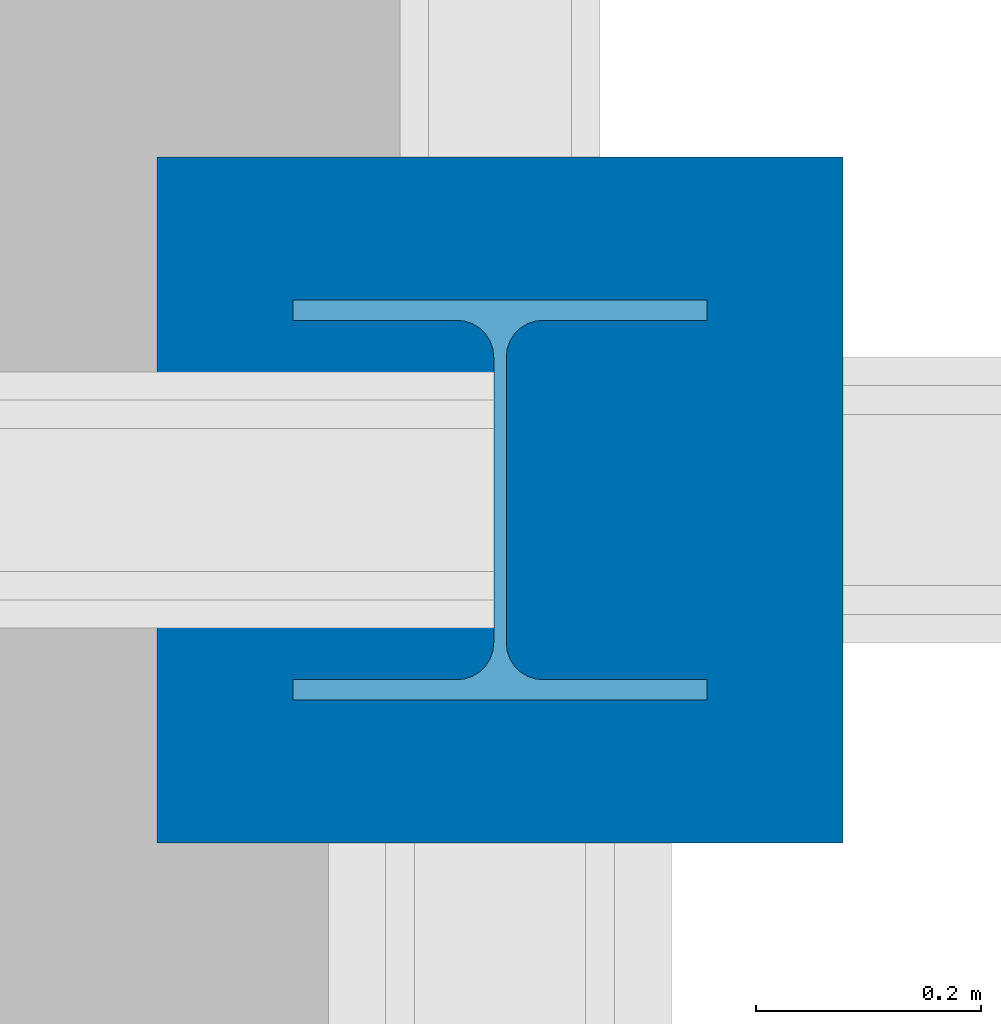
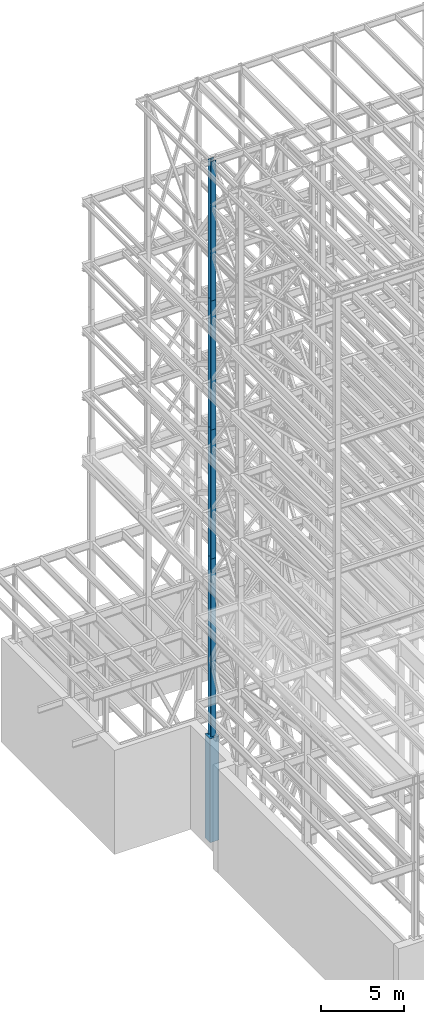
# One storey, part 14 of 150: 5 columns.
"""IFC2X3 building model written with IfcOpenShell, lengths in millimetres."""

from ifc_helpers import new_model, si_unit, frame, origin_with_axes, origin_2d_with_axis, place, context, subcontext, project, spatial, rectangle, i_section, extrude, material, type_object, element, save


model = new_model("IFC2X3")

# Units and contexts
model_context = context("Model", 3, precision=1e-05, world=origin_with_axes())
body_context = subcontext(model_context, "Body", "Model", "MODEL_VIEW")
ifc_project = project(units=[si_unit("LENGTHUNIT", "METRE", prefix="MILLI"), si_unit("AREAUNIT", "SQUARE_METRE"), si_unit("VOLUMEUNIT", "CUBIC_METRE"), si_unit("MASSUNIT", "GRAM", prefix="KILO"), si_unit("TIMEUNIT", "SECOND"), si_unit("PLANEANGLEUNIT", "RADIAN"), si_unit("SOLIDANGLEUNIT", "STERADIAN"), si_unit("THERMODYNAMICTEMPERATUREUNIT", "DEGREE_CELSIUS"), si_unit("LUMINOUSINTENSITYUNIT", "LUMEN")], contexts=[model_context])

# Site, building, storey
site_placement = place(None, origin_with_axes())
site = spatial("IfcSite", under=ifc_project, at=site_placement, CompositionType="ELEMENT")
building_placement = place(site_placement, origin_with_axes())
building = spatial("IfcBuilding", under=site, at=building_placement, Name="Undefined", CompositionType="ELEMENT")
storey_placement = place(building_placement, origin_with_axes())
storey = spatial("IfcBuildingStorey", under=building, at=storey_placement, Name="Undefined", CompositionType="ELEMENT", Elevation=0.0)

# Columns
ifc_material_1 = material(Name="STEEL/A992")
column_type_1 = type_object("IfcColumnType", Name="W14X90", PredefinedType="NOTDEFINED")
column_1_placement = place(storey_placement, frame((5283.2, 24384.0, 55702.2), z_axis=(0.0, 0.0, 1.0), x_axis=(1.0, 0.0, 0.0)))
element("IfcColumn", 1, at=column_1_placement, inside=storey, type_object=column_type_1, material=ifc_material_1, Name="COLUMN", ObjectType="W14X90", context=body_context, shape_type="SweptSolid", body=[
    extrude(i_section(OverallWidth=368.3, OverallDepth=355.6, WebThickness=11.1125, FlangeThickness=18.034, FilletRadius=32.7659, at=origin_2d_with_axis()), frame((0.0, 0.0, 10210.8), z_axis=(0.0, 0.0, -1.0), x_axis=(-1.0, 0.0, 0.0)), (0.0, 0.0, 1.0), 10210.8),
])
column_2_placement = place(storey_placement, frame((5283.2, 24384.0, 46253.3981868516), z_axis=(0.0, 0.0, 1.0), x_axis=(1.0, 0.0, 0.0)))
element("IfcColumn", 2, at=column_2_placement, inside=storey, type_object=column_type_1, material=ifc_material_1, Name="COLUMN", ObjectType="W14X90", context=body_context, shape_type="SweptSolid", body=[
    extrude(i_section(OverallWidth=368.3, OverallDepth=355.6, WebThickness=11.1125, FlangeThickness=18.034, FilletRadius=32.7659, at=origin_2d_with_axis()), frame((0.0, 0.0, 9448.80181314844), z_axis=(0.0, 0.0, -1.0), x_axis=(-1.0, 0.0, 0.0)), (0.0, 0.0, 1.0), 9448.80181314844),
])
column_3_placement = place(storey_placement, frame((5283.2, 24384.0, 36804.6), z_axis=(0.0, 0.0, 1.0), x_axis=(1.0, 0.0, 0.0)))
element("IfcColumn", 3, at=column_3_placement, inside=storey, type_object=column_type_1, material=ifc_material_1, Name="COLUMN", ObjectType="W14X90", context=body_context, shape_type="SweptSolid", body=[
    extrude(i_section(OverallWidth=368.3, OverallDepth=355.6, WebThickness=11.1125, FlangeThickness=18.034, FilletRadius=32.7659, at=origin_2d_with_axis()), frame((0.0, 0.0, 9448.79818685154), z_axis=(0.0, 0.0, -1.0), x_axis=(-1.0, 0.0, 0.0)), (0.0, 0.0, 1.0), 9448.79818685154),
])
column_4_placement = place(storey_placement, frame((5283.2, 24384.0, 22707.6), z_axis=(0.0, 0.0, 1.0), x_axis=(1.0, 0.0, 0.0)))
element("IfcColumn", 4, at=column_4_placement, inside=storey, type_object=column_type_1, material=ifc_material_1, Name="COLUMN", ObjectType="W14X90", context=body_context, shape_type="SweptSolid", body=[
    extrude(i_section(OverallWidth=368.3, OverallDepth=355.6, WebThickness=11.1125, FlangeThickness=18.034, FilletRadius=32.7659, at=origin_2d_with_axis()), frame((0.0, 0.0, 14097.0), z_axis=(0.0, 0.0, -1.0), x_axis=(-1.0, 0.0, 0.0)), (0.0, 0.0, 1.0), 14097.0),
])
ifc_material_2 = material(Name="CONCRETE/5000")
column_type_2 = type_object("IfcColumnType", PredefinedType="NOTDEFINED")
column_5_placement = place(storey_placement, frame((5283.19999999999, 24384.0, 16154.4), z_axis=(0.0, 0.0, 1.0), x_axis=(1.0, 0.0, 0.0)))
element("IfcColumn", 5, at=column_5_placement, inside=storey, type_object=column_type_2, material=ifc_material_2, Name="COLUMN", context=body_context, shape_type="SweptSolid", body=[
    extrude(rectangle(XDim=609.6, YDim=609.6, at=origin_2d_with_axis()), frame((0.0, 0.0, 7620.0), z_axis=(0.0, 0.0, -1.0), x_axis=(0.0, -1.0, 0.0)), (0.0, 0.0, 1.0), 7620.0),
])

save(model, "model.ifc")
